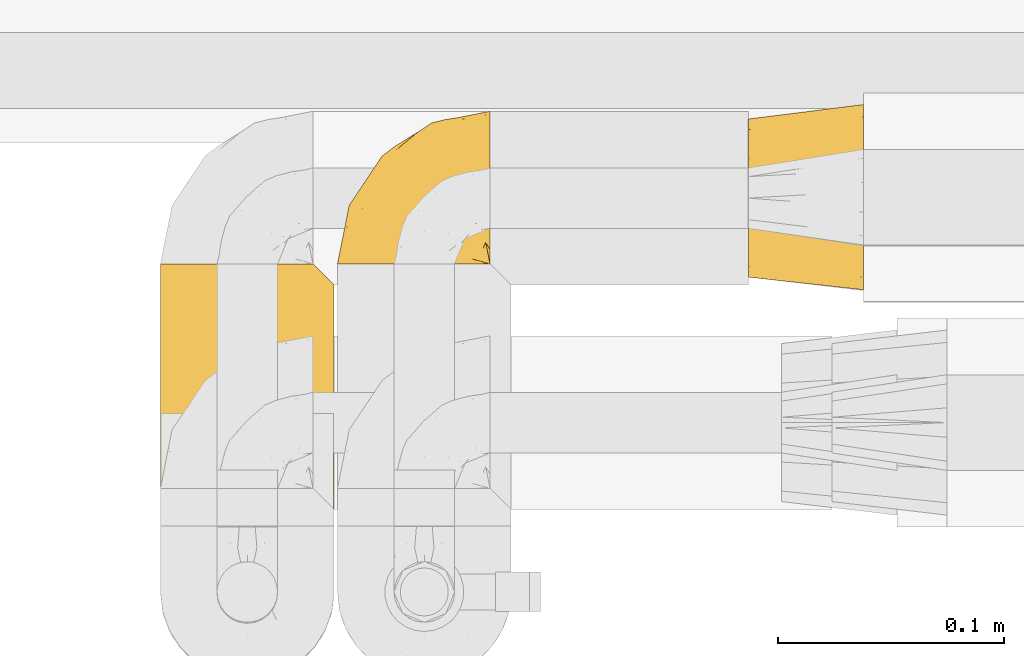
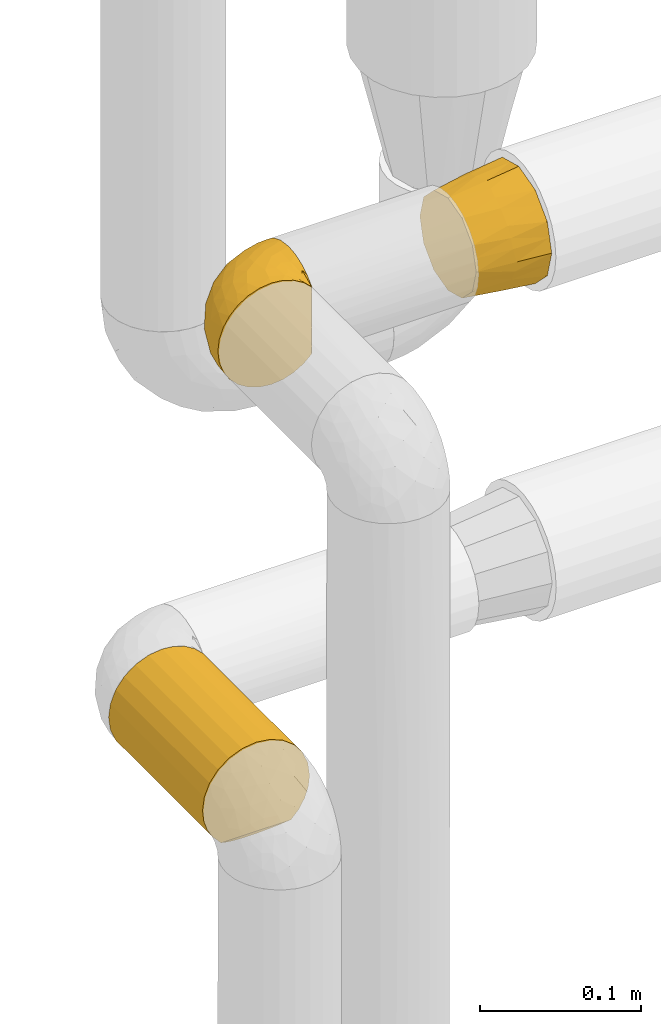
# One storey, part 468 of 827: 3 coverings.
"""IFC2X3 building model written with IfcOpenShell, lengths in millimetres."""

from ifc_helpers import new_model, entity, si_unit, converted_unit, derived_unit, direction, frame, origin, place, context, subcontext, project, spatial, faceted_brep, element, save


model = new_model("IFC2X3")

# Units and contexts
model_context = context("Model", 3, precision=0.01, world=origin(), true_north=direction((6.12303176911189e-17, 1.0)))
body_context = subcontext(model_context, "Body", "Model", "MODEL_VIEW")
ifc_project = project(units=[si_unit("LENGTHUNIT", "METRE", prefix="MILLI"), si_unit("AREAUNIT", "SQUARE_METRE"), si_unit("VOLUMEUNIT", "CUBIC_METRE"), converted_unit("PLANEANGLEUNIT", "DEGREE", entity("IfcRatioMeasure", 0.0174532925199433), si_unit("PLANEANGLEUNIT", "RADIAN"), dimensions=[0, 0, 0, 0, 0, 0, 0]), si_unit("MASSUNIT", "GRAM", prefix="KILO"), derived_unit("MASSDENSITYUNIT", [(si_unit("MASSUNIT", "GRAM", prefix="KILO"), 1), (si_unit("LENGTHUNIT", "METRE"), -3)]), derived_unit("MOMENTOFINERTIAUNIT", [(si_unit("LENGTHUNIT", "METRE"), 4)]), si_unit("TIMEUNIT", "SECOND"), si_unit("FREQUENCYUNIT", "HERTZ"), si_unit("THERMODYNAMICTEMPERATUREUNIT", "DEGREE_CELSIUS"), derived_unit("THERMALTRANSMITTANCEUNIT", [(si_unit("MASSUNIT", "GRAM", prefix="KILO"), 1), (si_unit("THERMODYNAMICTEMPERATUREUNIT", "KELVIN"), -1), (si_unit("TIMEUNIT", "SECOND"), -3)]), derived_unit("VOLUMETRICFLOWRATEUNIT", [(si_unit("LENGTHUNIT", "METRE"), 3), (si_unit("TIMEUNIT", "SECOND"), -1)]), derived_unit("MASSFLOWRATEUNIT", [(si_unit("MASSUNIT", "GRAM", prefix="KILO"), 1), (si_unit("TIMEUNIT", "SECOND"), -1)]), derived_unit("ROTATIONALFREQUENCYUNIT", [(si_unit("TIMEUNIT", "SECOND"), -1)]), si_unit("ELECTRICCURRENTUNIT", "AMPERE"), si_unit("ELECTRICVOLTAGEUNIT", "VOLT"), si_unit("POWERUNIT", "WATT"), si_unit("FORCEUNIT", "NEWTON", prefix="KILO"), si_unit("ILLUMINANCEUNIT", "LUX"), si_unit("LUMINOUSFLUXUNIT", "LUMEN"), si_unit("LUMINOUSINTENSITYUNIT", "CANDELA"), derived_unit("USERDEFINED", [(si_unit("MASSUNIT", "GRAM", prefix="KILO"), -1), (si_unit("LENGTHUNIT", "METRE"), -2), (si_unit("TIMEUNIT", "SECOND"), 3), (si_unit("LUMINOUSFLUXUNIT", "LUMEN"), 1)]), derived_unit("LINEARVELOCITYUNIT", [(si_unit("LENGTHUNIT", "METRE"), 1), (si_unit("TIMEUNIT", "SECOND"), -1)]), si_unit("PRESSUREUNIT", "PASCAL"), derived_unit("USERDEFINED", [(si_unit("LENGTHUNIT", "METRE"), -2), (si_unit("MASSUNIT", "GRAM", prefix="KILO"), 1), (si_unit("TIMEUNIT", "SECOND"), -2)]), derived_unit("LINEARFORCEUNIT", [(si_unit("MASSUNIT", "GRAM", prefix="KILO"), 1), (si_unit("LENGTHUNIT", "METRE"), 1), (si_unit("TIMEUNIT", "SECOND"), -2), (si_unit("LENGTHUNIT", "METRE"), -1)]), derived_unit("PLANARFORCEUNIT", [(si_unit("MASSUNIT", "GRAM", prefix="KILO"), 1), (si_unit("LENGTHUNIT", "METRE"), 1), (si_unit("TIMEUNIT", "SECOND"), -2), (si_unit("LENGTHUNIT", "METRE"), -2)])], contexts=[model_context])

# Site, building, storey
site_placement = place(None, origin())
site = spatial("IfcSite", under=ifc_project, at=site_placement, CompositionType="ELEMENT")
building_placement = place(site_placement, origin())
building = spatial("IfcBuilding", under=site, at=building_placement, CompositionType="ELEMENT")
storey_placement = place(building_placement, frame((0.0, 0.0, 28200.0)))
storey = spatial("IfcBuildingStorey", under=building, at=storey_placement, Name="08", CompositionType="ELEMENT", Elevation=28200.0)

# Coverings
covering_1_placement = place(storey_placement, frame((58529.55, 16448.53, 1209.95)))
element("IfcCovering", 1, at=covering_1_placement, inside=storey, Name=":ADSK_", ObjectType=":ADSK_", PredefinedType="INSULATION", context=body_context, shape_type="Brep", body=[
    faceted_brep([(23.36, 1.6, 74.68), (16.07, 1.6, 70.1), (9.98, 1.6, 64.01), (5.4, 1.6, 56.72), (2.56, 1.6, 48.6), (1.6, 1.6, 40.05), (2.56, 1.6, 31.49), (5.41, 1.6, 23.36), (9.99, 1.6, 16.07), (16.08, 1.6, 9.98), (23.37, 1.6, 5.4), (31.49, 1.6, 2.56), (40.05, 1.6, 1.6), (48.15, 1.6, 2.46), (55.88, 1.6, 5.01), (62.9, 1.6, 9.13), (68.89, 1.6, 14.62), (68.89, 1.6, 16.82), (68.89, 1.6, 18.56), (68.89, 1.6, 20.52), (68.89, 1.6, 22.49), (68.89, 1.6, 24.46), (68.89, 1.6, 26.42), (68.89, 1.6, 28.39), (68.89, 1.6, 30.36), (68.89, 1.6, 32.55), (68.89, 1.6, 34.75), (68.89, 1.6, 36.94), (68.89, 1.6, 39.13), (68.89, 1.6, 41.33), (68.89, 1.6, 43.52), (68.89, 1.6, 45.72), (68.89, 1.6, 47.91), (68.89, 1.6, 50.11), (68.89, 1.6, 52.3), (68.89, 1.6, 54.49), (68.89, 1.6, 56.69), (68.89, 1.6, 58.88), (68.89, 1.6, 61.08), (68.89, 1.6, 63.27), (68.89, 1.6, 65.47), (62.89, 1.6, 70.97), (55.86, 1.6, 75.09), (48.13, 1.6, 77.64), (40.05, 1.6, 78.5), (31.49, 1.6, 77.53), (69.15, 1.85, 14.62), (69.15, 7.85, 9.12), (69.15, 14.87, 5.0), (69.15, 22.6, 2.46), (69.15, 30.7, 1.6), (69.15, 40.65, 2.91), (69.15, 49.92, 6.75), (69.15, 57.88, 12.86), (69.15, 63.99, 20.82), (69.15, 67.84, 30.09), (69.15, 69.15, 40.05), (69.15, 67.84, 50.0), (69.15, 63.99, 59.27), (69.15, 57.88, 67.23), (69.15, 49.92, 73.34), (69.15, 40.65, 77.19), (69.15, 30.7, 78.5), (69.15, 22.6, 77.63), (69.15, 14.87, 75.09), (69.15, 7.85, 70.97), (69.15, 1.85, 65.47), (69.15, 1.85, 63.27), (69.15, 1.85, 62.29), (69.15, 1.85, 60.7), (69.15, 1.85, 59.11), (69.15, 1.85, 57.52), (69.15, 1.85, 55.93), (69.15, 1.85, 54.34), (69.15, 1.85, 52.76), (69.15, 1.85, 51.17), (69.15, 1.85, 49.58), (69.15, 1.85, 47.99), (69.15, 1.85, 46.4), (69.15, 1.85, 44.81), (69.15, 1.85, 43.22), (69.15, 1.85, 41.63), (69.15, 1.85, 40.05), (69.15, 1.85, 38.46), (69.15, 1.85, 36.87), (69.15, 1.85, 35.28), (69.15, 1.85, 33.69), (69.15, 1.85, 32.1), (69.15, 1.85, 30.51), (69.15, 1.85, 28.92), (69.15, 1.85, 27.33), (69.15, 1.85, 25.37), (69.15, 1.85, 23.4), (69.15, 1.85, 21.21), (69.15, 1.85, 19.01), (69.15, 1.85, 16.82), (68.96, 1.77, 42.32), (68.97, 1.78, 44.02), (68.97, 1.77, 47.13), (68.97, 1.77, 48.74), (68.95, 1.76, 23.57), (68.96, 1.77, 25.13), (68.98, 1.79, 61.34), (68.97, 1.78, 22.02), (68.97, 1.78, 29.72), (68.98, 1.78, 56.73), (68.97, 1.78, 55.14), (68.97, 1.78, 37.66), (68.94, 1.74, 64.12), (68.98, 1.78, 28.13), (68.98, 1.78, 26.62), (68.96, 1.77, 31.46), (68.97, 1.78, 16.16), (68.98, 1.78, 39.16), (68.98, 1.78, 50.37), (68.97, 1.77, 17.69), (68.96, 1.77, 19.17), (68.97, 1.77, 62.78), (68.97, 1.78, 58.35), (68.98, 1.78, 45.53), (68.96, 1.77, 59.91), (68.97, 1.77, 65.47), (68.94, 1.72, 65.47), (68.92, 1.66, 65.47), (68.97, 1.77, 14.62), (69.02, 1.8, 14.62), (69.08, 1.82, 14.62), (68.98, 1.79, 20.59), (68.97, 1.78, 32.99), (68.98, 1.79, 34.48), (68.97, 1.78, 51.91), (69.08, 1.82, 65.47), (69.02, 1.8, 65.47), (68.96, 1.76, 53.48), (68.92, 1.66, 14.62), (68.94, 1.72, 14.62), (68.97, 1.78, 40.77), (68.96, 1.77, 35.97), (67.02, 9.41, 7.84), (63.33, 17.65, 3.53), (64.61, 7.41, 8.32), (49.27, 21.47, 1.6), (51.4, 15.21, 2.19), (43.94, 16.15, 1.6), (61.87, 28.75, 1.6), (61.54, 13.67, 4.57), (57.95, 12.79, 3.96), (56.12, 19.18, 2.28), (63.4, 29.16, 1.6), (65.41, 9.04, 7.69), (53.1, 7.41, 3.53), (63.04, 5.74, 8.32), (61.33, 3.72, 7.84), (41.99, 8.87, 1.6), (54.6, 26.8, 1.6), (56.6, 9.53, 4.34), (41.58, 7.34, 1.6), (13.72, 37.63, 29.63), (5.82, 17.92, 27.34), (6.74, 27.45, 40.05), (58.82, 37.01, 2.39), (51.58, 34.22, 2.43), (42.09, 45.87, 9.07), (46.12, 56.57, 16.64), (55.56, 52.31, 9.54), (52.38, 42.07, 4.52), (61.54, 44.74, 4.52), (23.76, 21.49, 7.49), (20.5, 11.02, 7.49), (14.64, 15.64, 12.85), (41.77, 26.02, 2.35), (16.28, 36.59, 22.66), (49.4, 65.49, 32.9), (52.34, 63.99, 25.33), (4.3, 15.2, 40.05), (58.67, 60.27, 16.64), (25.26, 45.25, 19.99), (20.17, 35.21, 16.37), (34.7, 22.52, 3.26), (28.67, 12.03, 3.75), (8.62, 13.32, 19.58), (33.37, 35.9, 7.5), (41.35, 33.87, 4.04), (17.15, 25.73, 13.94), (12.68, 26.34, 19.58), (21.47, 46.78, 28.21), (41.11, 59.54, 24.75), (37.53, 60.18, 31.42), (30.64, 53.93, 26.2), (26.66, 53.36, 33.36), (21.38, 49.36, 40.05), (14.06, 38.4, 40.05), (55.54, 66.44, 40.05), (35.17, 50.09, 16.14), (29.04, 41.08, 12.85), (24.34, 31.14, 10.47), (29.33, 28.19, 6.49), (43.3, 64.0, 40.05), (32.34, 56.68, 40.05), (57.75, 43.9, 75.57), (49.41, 65.46, 47.37), (27.85, 52.22, 52.91), (13.7, 37.61, 50.46), (14.63, 15.64, 67.23), (8.61, 13.31, 60.5), (48.85, 50.02, 70.55), (54.13, 59.28, 63.45), (37.84, 53.05, 62.61), (23.75, 21.48, 72.6), (20.49, 11.01, 72.6), (28.66, 12.03, 76.34), (20.83, 41.02, 59.34), (55.15, 35.39, 77.76), (54.6, 26.8, 78.5), (61.87, 28.75, 78.5), (41.58, 7.34, 78.5), (57.58, 65.81, 53.16), (59.91, 53.28, 70.55), (36.94, 59.8, 48.88), (45.72, 61.82, 54.76), (5.82, 17.91, 52.74), (37.91, 41.4, 71.93), (50.18, 40.48, 75.79), (12.67, 26.34, 60.5), (49.29, 31.68, 77.86), (42.64, 27.68, 77.64), (43.94, 16.15, 78.5), (49.27, 21.47, 78.5), (19.45, 28.05, 67.23), (34.7, 22.54, 76.82), (41.99, 8.87, 78.5), (62.29, 37.3, 77.8), (29.01, 41.07, 67.23), (31.47, 32.24, 73.2), (37.18, 47.4, 67.66), (43.45, 35.77, 75.99), (63.33, 17.65, 76.57), (67.23, 11.06, 73.21), (66.07, 8.55, 71.93), (65.22, 6.63, 71.07), (61.99, 12.77, 75.09), (57.95, 12.79, 76.13), (53.09, 7.41, 76.57), (56.84, 18.97, 77.69), (61.33, 3.72, 72.26), (63.06, 5.76, 71.77), (51.41, 15.21, 77.9), (56.61, 9.52, 75.75)], [[[0, 1, 2, 3, 4, 5, 6, 7, 8, 9, 10, 11, 12, 13, 14, 15, 16, 17, 18, 19, 20, 21, 22, 23, 24, 25, 26, 27, 28, 29, 30, 31, 32, 33, 34, 35, 36, 37, 38, 39, 40, 41, 42, 43, 44, 45]], [[46, 47, 48, 49, 50, 51, 52, 53, 54, 55, 56, 57, 58, 59, 60, 61, 62, 63, 64, 65, 66, 67, 68, 69, 70, 71, 72, 73, 74, 75, 76, 77, 78, 79, 80, 81, 82, 83, 84, 85, 86, 87, 88, 89, 90, 91, 92, 93, 94, 95]], [[96, 97, 30]], [[98, 77, 99]], [[100, 101, 21]], [[69, 68, 102]], [[20, 19, 103]], [[24, 23, 104]], [[20, 103, 100]], [[72, 105, 106]], [[84, 83, 107]], [[89, 88, 104]], [[108, 67, 66]], [[109, 110, 90]], [[111, 25, 24]], [[112, 17, 16]], [[82, 113, 83]], [[109, 23, 22]], [[114, 76, 75]], [[105, 36, 106]], [[104, 111, 24]], [[18, 115, 116]], [[97, 96, 80]], [[67, 108, 117]], [[105, 71, 118]], [[31, 97, 119]], [[102, 120, 69]], [[108, 121, 122, 123, 40]], [[112, 95, 115]], [[17, 115, 18]], [[94, 116, 115]], [[117, 68, 67]], [[38, 117, 39]], [[112, 124, 125, 126, 46]], [[17, 112, 115]], [[70, 120, 118]], [[39, 117, 108]], [[120, 38, 37]], [[120, 37, 118]], [[120, 70, 69]], [[116, 94, 127]], [[128, 86, 129]], [[117, 38, 102]], [[74, 130, 75]], [[99, 33, 32]], [[115, 95, 94]], [[39, 108, 40]], [[108, 66, 131, 132, 121]], [[105, 72, 71]], [[118, 37, 36]], [[71, 70, 118]], [[35, 106, 36]], [[36, 105, 118]], [[35, 133, 106]], [[74, 73, 133]], [[106, 133, 73]], [[99, 114, 33]], [[133, 35, 34]], [[73, 72, 106]], [[95, 112, 46]], [[112, 16, 134, 135, 124]], [[130, 114, 75]], [[99, 76, 114]], [[114, 130, 33]], [[34, 33, 130]], [[78, 77, 98]], [[98, 119, 78]], [[130, 133, 34]], [[133, 130, 74]], [[79, 97, 80]], [[98, 99, 32]], [[98, 32, 31]], [[77, 76, 99]], [[97, 79, 119]], [[136, 96, 29]], [[30, 97, 31]], [[136, 29, 28]], [[81, 80, 96]], [[29, 96, 30]], [[31, 119, 98]], [[119, 79, 78]], [[96, 136, 81]], [[82, 81, 136]], [[113, 107, 83]], [[84, 107, 137]], [[107, 27, 137]], [[113, 28, 107]], [[27, 107, 28]], [[85, 84, 137]], [[137, 27, 26]], [[113, 136, 28]], [[136, 113, 82]], [[109, 89, 104]], [[86, 85, 129]], [[89, 109, 90]], [[111, 87, 128]], [[26, 129, 137]], [[88, 111, 104]], [[25, 111, 128]], [[22, 110, 109]], [[23, 109, 104]], [[110, 91, 90]], [[100, 92, 101]], [[110, 22, 101]], [[91, 110, 101]], [[116, 19, 18]], [[111, 88, 87]], [[127, 103, 19]], [[25, 128, 26]], [[86, 128, 87]], [[128, 129, 26]], [[137, 129, 85]], [[120, 102, 38]], [[117, 102, 68]], [[91, 101, 92]], [[21, 101, 22]], [[93, 92, 103]], [[100, 21, 20]], [[100, 103, 92]], [[127, 93, 103]], [[93, 127, 94]], [[116, 127, 19]], [[126, 138, 47]], [[48, 138, 139]], [[140, 125, 124]], [[141, 142, 143]], [[144, 49, 139]], [[145, 140, 146]], [[48, 139, 49]], [[139, 145, 147]], [[49, 144, 148, 50]], [[126, 125, 149]], [[14, 13, 150]], [[151, 146, 140]], [[149, 140, 145]], [[152, 151, 135]], [[152, 14, 150]], [[16, 15, 134]], [[13, 153, 150]], [[124, 151, 140]], [[141, 147, 142]], [[14, 152, 15]], [[15, 152, 134]], [[47, 46, 126]], [[139, 154, 144]], [[138, 48, 47]], [[125, 140, 149]], [[135, 134, 152]], [[146, 155, 142]], [[145, 146, 147]], [[149, 139, 138]], [[147, 141, 154]], [[147, 146, 142]], [[139, 147, 154]], [[139, 149, 145]], [[149, 138, 126]], [[155, 146, 151]], [[150, 143, 142]], [[152, 155, 151]], [[150, 142, 155]], [[13, 12, 156, 153]], [[153, 143, 150]], [[152, 150, 155]], [[151, 124, 135]], [[157, 158, 159]], [[160, 154, 161]], [[162, 163, 164]], [[165, 166, 160]], [[167, 168, 169]], [[141, 170, 161]], [[156, 12, 11]], [[158, 157, 171]], [[172, 55, 173]], [[158, 6, 174]], [[175, 54, 53]], [[52, 166, 164]], [[52, 164, 53]], [[54, 175, 173]], [[166, 52, 51]], [[176, 177, 171]], [[178, 143, 179]], [[156, 11, 179]], [[8, 7, 180]], [[169, 9, 8]], [[179, 143, 153, 156]], [[179, 11, 10]], [[168, 179, 10]], [[181, 162, 182]], [[179, 167, 178]], [[183, 184, 177]], [[183, 169, 184]], [[176, 171, 185]], [[172, 186, 187]], [[158, 7, 6]], [[159, 158, 174]], [[184, 180, 158]], [[54, 173, 55]], [[180, 169, 8]], [[188, 189, 187]], [[9, 168, 10]], [[186, 188, 187]], [[190, 157, 159, 191]], [[55, 172, 192]], [[176, 193, 194]], [[161, 170, 182]], [[162, 164, 165]], [[175, 164, 163]], [[51, 50, 148]], [[167, 195, 196]], [[178, 182, 170]], [[6, 5, 174]], [[158, 180, 7]], [[169, 180, 184]], [[169, 168, 9]], [[179, 168, 167]], [[182, 162, 165]], [[162, 194, 193]], [[161, 165, 160]], [[195, 181, 196]], [[192, 172, 197]], [[192, 56, 55]], [[189, 190, 198]], [[198, 197, 187]], [[172, 187, 197]], [[185, 189, 188]], [[198, 187, 189]], [[186, 172, 173]], [[173, 163, 186]], [[193, 186, 163]], [[176, 185, 188]], [[185, 157, 190]], [[188, 186, 193]], [[177, 176, 194]], [[188, 193, 176]], [[162, 193, 163]], [[195, 177, 194]], [[171, 177, 184]], [[181, 195, 194]], [[183, 167, 169]], [[162, 181, 194]], [[196, 182, 178]], [[158, 171, 184]], [[171, 157, 185]], [[177, 195, 183]], [[167, 183, 195]], [[182, 196, 181]], [[178, 170, 143]], [[178, 167, 196]], [[164, 175, 53]], [[173, 175, 163]], [[160, 51, 148]], [[164, 166, 165]], [[51, 160, 166]], [[160, 148, 144, 154]], [[141, 161, 154]], [[182, 165, 161]], [[190, 189, 185]], [[143, 170, 141]], [[60, 199, 61]], [[197, 200, 192]], [[201, 190, 202]], [[200, 57, 192]], [[203, 204, 2]], [[205, 206, 207]], [[208, 209, 210]], [[211, 207, 201]], [[212, 213, 214]], [[45, 215, 210]], [[216, 206, 58]], [[45, 44, 215]], [[59, 217, 60]], [[60, 217, 199]], [[0, 45, 210]], [[218, 201, 219]], [[202, 159, 220]], [[205, 221, 222]], [[223, 204, 203]], [[1, 203, 2]], [[57, 200, 216]], [[220, 3, 204]], [[220, 174, 4]], [[1, 0, 209]], [[212, 224, 213]], [[225, 226, 227]], [[228, 223, 203]], [[208, 210, 229]], [[210, 226, 229]], [[3, 220, 4]], [[58, 206, 59]], [[209, 203, 1]], [[202, 220, 223]], [[228, 203, 208]], [[202, 211, 201]], [[3, 2, 204]], [[202, 190, 191, 159]], [[210, 215, 230, 226]], [[199, 212, 231]], [[232, 233, 221]], [[233, 208, 229]], [[207, 206, 219]], [[217, 206, 205]], [[227, 224, 225]], [[233, 232, 228]], [[201, 207, 219]], [[234, 232, 221]], [[218, 219, 200]], [[202, 223, 211]], [[174, 220, 159]], [[174, 5, 4]], [[61, 231, 62]], [[220, 204, 223]], [[210, 209, 0]], [[203, 209, 208]], [[225, 233, 229]], [[224, 227, 213]], [[221, 233, 235]], [[57, 56, 192]], [[198, 218, 197]], [[200, 219, 216]], [[201, 198, 190]], [[197, 218, 200]], [[198, 201, 218]], [[206, 216, 219]], [[58, 57, 216]], [[231, 212, 214]], [[222, 212, 199]], [[228, 211, 223]], [[207, 211, 232]], [[62, 231, 214]], [[199, 231, 61]], [[233, 228, 208]], [[211, 228, 232]], [[222, 221, 235]], [[234, 205, 207]], [[206, 217, 59]], [[199, 217, 205]], [[205, 222, 199]], [[224, 222, 235]], [[222, 224, 212]], [[224, 235, 225]], [[233, 225, 235]], [[226, 225, 229]], [[205, 234, 221]], [[207, 232, 234]], [[63, 214, 236]], [[214, 213, 236]], [[214, 63, 62]], [[237, 236, 238]], [[238, 132, 131]], [[236, 237, 64]], [[239, 240, 241]], [[63, 236, 64]], [[131, 66, 65]], [[237, 131, 65]], [[242, 230, 43]], [[237, 65, 64]], [[239, 121, 132]], [[42, 242, 43]], [[241, 240, 243]], [[41, 123, 244]], [[43, 230, 215, 44]], [[244, 122, 245]], [[227, 246, 243]], [[241, 247, 245]], [[121, 239, 245]], [[41, 40, 123]], [[132, 238, 239]], [[244, 42, 41]], [[131, 237, 238]], [[240, 239, 238]], [[245, 239, 241]], [[247, 241, 246]], [[247, 244, 245]], [[238, 236, 240]], [[243, 236, 213]], [[236, 243, 240]], [[227, 226, 246]], [[243, 213, 227]], [[242, 246, 226]], [[243, 246, 241]], [[246, 242, 247]], [[244, 247, 242]], [[242, 226, 230]], [[42, 244, 242]], [[122, 244, 123]], [[122, 121, 245]]]),
])
covering_2_placement = place(storey_placement, frame((58713.02, 16437.06, 1207.4)))
element("IfcCovering", 2, at=covering_2_placement, inside=storey, Name=":ADSK_", ObjectType=":ADSK_", PredefinedType="INSULATION", context=body_context, shape_type="Brep", body=[
    faceted_brep([(51.0, 14.59, 70.6), (51.0, 7.09, 63.1), (51.0, 4.34, 52.85), (51.0, 1.6, 42.6), (51.0, 4.34, 32.35), (51.0, 7.09, 22.1), (51.0, 14.59, 14.59), (51.0, 22.1, 7.09), (51.0, 32.35, 4.34), (51.0, 42.6, 1.6), (51.0, 52.85, 4.34), (51.0, 63.1, 7.09), (51.0, 70.6, 14.59), (51.0, 78.1, 22.1), (51.0, 80.85, 32.35), (51.0, 83.6, 42.6), (51.0, 80.85, 52.85), (51.0, 78.1, 63.1), (51.0, 70.6, 70.6), (51.0, 63.1, 78.1), (51.0, 52.85, 80.85), (51.0, 42.6, 83.6), (51.0, 32.35, 80.85), (51.0, 22.1, 78.1), (0.0, 7.17, 42.6), (0.0, 9.51, 51.35), (0.0, 11.86, 60.1), (0.0, 18.26, 66.5), (0.0, 24.67, 72.91), (0.0, 35.18, 75.72), (0.0, 42.17, 77.6), (0.0, 50.92, 75.25), (0.0, 59.67, 72.91), (0.0, 66.07, 66.5), (0.0, 72.48, 60.1), (0.0, 75.29, 49.58), (0.0, 77.17, 42.6), (0.0, 74.82, 33.85), (0.0, 72.48, 25.1), (0.0, 66.07, 18.69), (0.0, 59.67, 12.28), (0.0, 49.15, 9.47), (0.0, 42.17, 7.6), (0.0, 33.42, 9.94), (0.0, 24.67, 12.28), (0.0, 18.26, 18.69), (0.0, 11.86, 25.1), (0.0, 9.04, 35.61), (25.5, 7.27, 28.05), (26.64, 4.99, 35.15), (25.5, 11.06, 21.08), (27.5, 42.4, 4.36), (25.5, 19.25, 12.45), (25.5, 26.01, 8.3), (27.5, 4.16, 42.6), (25.5, 32.94, 5.79), (25.5, 56.92, 7.49), (26.64, 49.83, 5.19), (25.5, 63.89, 11.27), (27.48, 80.63, 42.6), (25.5, 72.53, 19.46), (25.5, 76.67, 26.22), (25.5, 79.19, 33.15), (25.5, 77.49, 57.14), (26.64, 79.79, 50.04), (25.5, 73.7, 64.11), (27.48, 42.4, 80.83), (25.5, 65.51, 72.74), (25.5, 58.75, 76.89), (25.5, 51.83, 79.4), (25.5, 27.84, 77.7), (26.64, 34.95, 80.0), (25.5, 20.87, 73.92), (25.5, 12.23, 65.73), (25.5, 8.09, 58.97), (25.5, 5.57, 52.04)], [[[0, 1, 2, 3, 4, 5, 6, 7, 8, 9, 10, 11, 12, 13, 14, 15, 16, 17, 18, 19, 20, 21, 22, 23]], [[24, 25, 26, 27, 28, 29, 30, 31, 32, 33, 34, 35, 36, 37, 38, 39, 40, 41, 42, 43, 44, 45, 46, 47]], [[47, 48, 49]], [[49, 24, 47]], [[48, 47, 46]], [[5, 4, 48]], [[50, 5, 48]], [[48, 4, 49]], [[51, 9, 8]], [[52, 50, 45]], [[50, 48, 46]], [[7, 52, 53]], [[53, 52, 44]], [[45, 44, 52]], [[50, 46, 45]], [[54, 24, 49, 3]], [[52, 6, 50]], [[6, 5, 50]], [[6, 52, 7]], [[55, 8, 53]], [[53, 43, 55]], [[53, 44, 43]], [[3, 49, 4]], [[8, 7, 53]], [[42, 51, 55]], [[42, 55, 43]], [[51, 8, 55]], [[41, 56, 57]], [[57, 42, 41]], [[56, 41, 40]], [[11, 10, 56]], [[58, 11, 56]], [[56, 10, 57]], [[59, 15, 14]], [[60, 58, 39]], [[58, 56, 40]], [[13, 60, 61]], [[61, 60, 38]], [[39, 38, 60]], [[58, 40, 39]], [[51, 42, 57, 9]], [[60, 12, 58]], [[12, 11, 58]], [[12, 60, 13]], [[62, 14, 61]], [[61, 37, 62]], [[61, 38, 37]], [[9, 57, 10]], [[14, 13, 61]], [[36, 59, 62]], [[36, 62, 37]], [[59, 14, 62]], [[35, 63, 64]], [[64, 36, 35]], [[63, 35, 34]], [[17, 16, 63]], [[65, 17, 63]], [[63, 16, 64]], [[66, 21, 20]], [[67, 65, 33]], [[65, 63, 34]], [[19, 67, 68]], [[68, 67, 32]], [[33, 32, 67]], [[65, 34, 33]], [[59, 36, 64, 15]], [[67, 18, 65]], [[18, 17, 65]], [[18, 67, 19]], [[69, 20, 68]], [[68, 31, 69]], [[68, 32, 31]], [[15, 64, 16]], [[20, 19, 68]], [[30, 66, 69]], [[30, 69, 31]], [[66, 20, 69]], [[29, 70, 71]], [[71, 30, 29]], [[70, 29, 28]], [[23, 22, 70]], [[72, 23, 70]], [[70, 22, 71]], [[54, 3, 2]], [[73, 72, 27]], [[72, 70, 28]], [[1, 73, 74]], [[74, 73, 26]], [[27, 26, 73]], [[72, 28, 27]], [[66, 30, 71, 21]], [[73, 0, 72]], [[0, 23, 72]], [[0, 73, 1]], [[75, 2, 74]], [[74, 25, 75]], [[74, 26, 25]], [[21, 71, 22]], [[2, 1, 74]], [[24, 54, 75]], [[24, 75, 25]], [[54, 2, 75]]]),
])
covering_3_placement = place(storey_placement, frame((58451.2, 16331.89, 960.0)))
element("IfcCovering", 3, at=covering_3_placement, inside=storey, Name=":ADSK_", ObjectType=":ADSK_", PredefinedType="INSULATION", context=body_context, shape_type="Brep", body=[
    faceted_brep([(5.09, 1.6, 23.98), (9.31, 1.6, 16.91), (14.94, 1.6, 10.9), (65.05, 1.6, 10.9), (70.68, 1.6, 16.91), (74.9, 1.6, 23.98), (77.51, 1.6, 31.79), (78.4, 1.6, 40.0), (77.09, 1.6, 49.93), (73.25, 1.6, 59.2), (67.15, 1.6, 67.15), (59.2, 1.6, 73.25), (49.93, 1.6, 77.09), (40.0, 1.6, 78.4), (30.06, 1.6, 77.09), (20.8, 1.6, 73.25), (12.84, 1.6, 67.15), (6.74, 1.6, 59.2), (2.9, 1.6, 49.93), (1.6, 1.6, 40.0), (2.48, 1.6, 31.79), (30.06, 118.23, 2.9), (20.8, 118.23, 6.74), (12.84, 118.23, 12.84), (6.74, 118.23, 20.8), (2.9, 118.23, 30.06), (1.6, 118.23, 40.0), (2.9, 118.23, 49.93), (6.74, 118.23, 59.2), (12.84, 118.23, 67.15), (20.8, 118.23, 73.25), (30.06, 118.23, 77.09), (40.0, 118.23, 78.4), (48.2, 118.23, 77.51), (56.01, 118.23, 74.9), (63.08, 118.23, 70.68), (69.1, 118.23, 65.05), (69.1, 118.23, 14.94), (63.08, 118.23, 9.31), (56.01, 118.23, 5.09), (48.2, 118.23, 2.48), (40.0, 118.23, 1.6), (26.63, 8.5, 4.0), (33.21, 10.29, 2.2), (40.0, 10.9, 1.6), (20.48, 5.57, 6.92), (46.78, 10.29, 2.2), (53.36, 8.5, 4.0), (59.51, 5.57, 6.92), (73.07, 114.26, 20.48), (76.0, 111.33, 26.63), (77.79, 109.54, 33.21), (78.4, 108.93, 40.0), (77.79, 109.54, 46.78), (76.0, 111.33, 53.36), (73.07, 114.26, 59.51)], [[[0, 1, 2, 3, 4, 5, 6, 7, 8, 9, 10, 11, 12, 13, 14, 15, 16, 17, 18, 19, 20]], [[21, 22, 23, 24, 25, 26, 27, 28, 29, 30, 31, 32, 33, 34, 35, 36, 37, 38, 39, 40, 41]], [[26, 25, 20]], [[25, 24, 0]], [[1, 24, 23]], [[20, 19, 26]], [[0, 20, 25]], [[24, 1, 0]], [[23, 2, 1]], [[42, 22, 21]], [[21, 41, 43]], [[44, 43, 41]], [[45, 2, 22]], [[43, 42, 21]], [[45, 22, 42]], [[22, 2, 23]], [[46, 41, 40]], [[47, 40, 39]], [[48, 39, 38]], [[46, 44, 41]], [[48, 47, 39]], [[3, 48, 38]], [[46, 40, 47]], [[38, 37, 3]], [[37, 49, 4]], [[50, 51, 6]], [[49, 50, 5]], [[4, 49, 5]], [[51, 7, 6]], [[6, 5, 50]], [[7, 51, 52]], [[37, 4, 3]], [[53, 54, 8]], [[55, 36, 9]], [[54, 55, 9]], [[52, 53, 7]], [[7, 53, 8]], [[54, 9, 8]], [[36, 10, 9]], [[11, 35, 34]], [[12, 34, 33]], [[13, 33, 32]], [[10, 35, 11]], [[11, 34, 12]], [[33, 13, 12]], [[35, 10, 36]], [[14, 13, 32, 31]], [[15, 14, 31, 30]], [[30, 29, 16, 15]], [[18, 17, 28, 27]], [[19, 18, 27, 26]], [[29, 28, 17, 16]], [[45, 42, 43, 44, 46, 47, 48, 3, 2]], [[36, 55, 54, 53, 52, 51, 50, 49, 37]]]),
])

save(model, "model.ifc")
